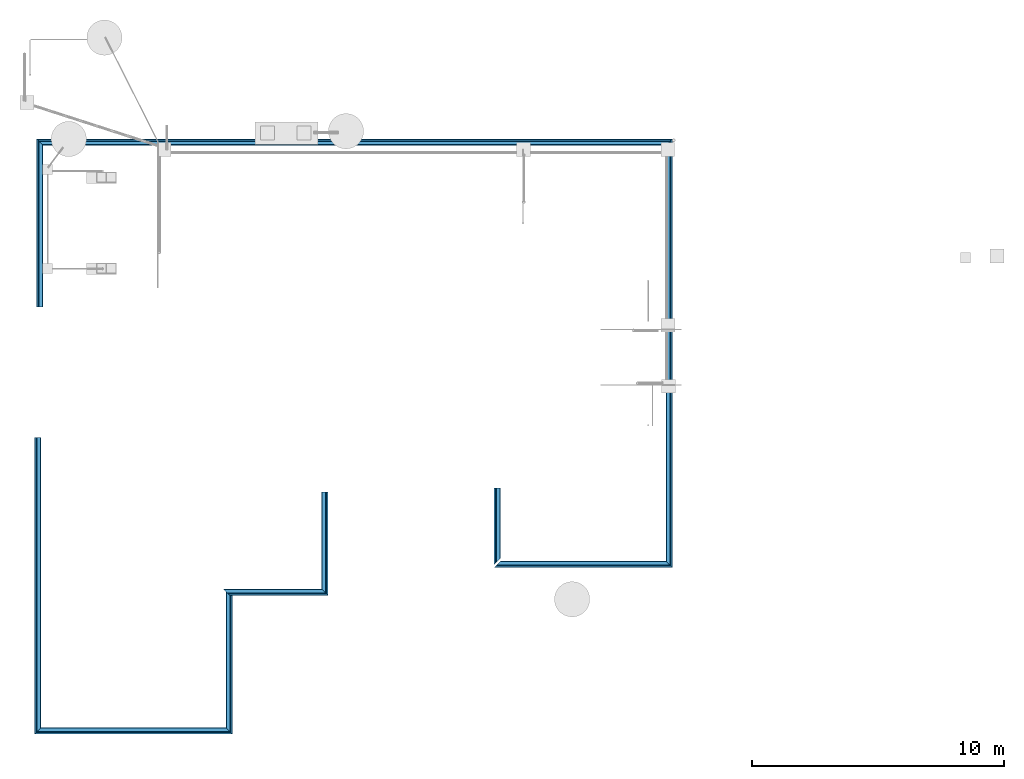
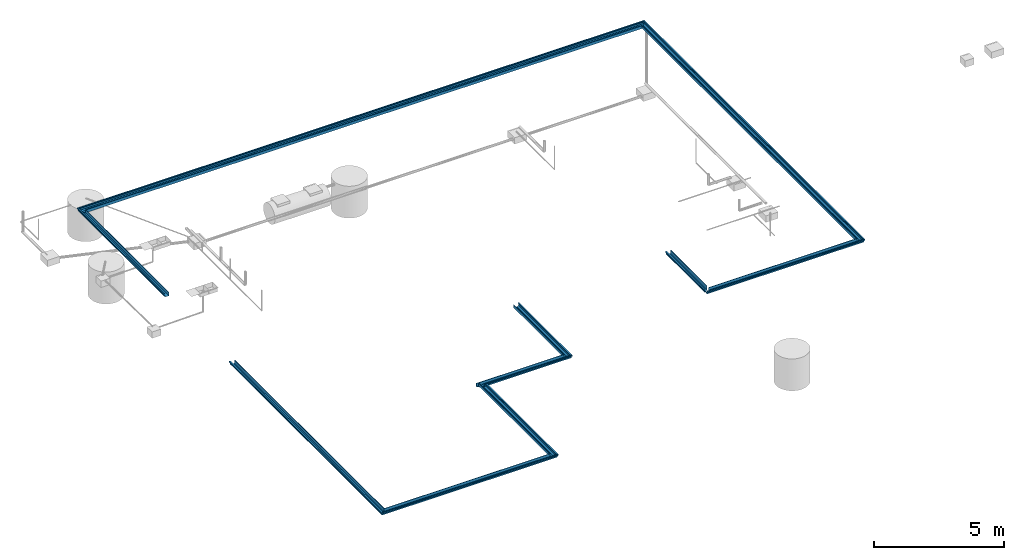
# One storey, part 1 of 15: 10 beams.
"""IFC4X3_ADD2 building model written with IfcOpenShell, lengths in metres."""

from ifc_helpers import new_model, entity, si_unit, converted_unit, frame, origin_with_axes, origin_2d_with_axis, place, context, subcontext, project, spatial, indexed_curve, outline, extrude, clip, halfspace, material, material_profile, profile_set, profile_usage, type_object, element, save


model = new_model("IFC4X3_ADD2")

# Units and contexts
model_context = context("Model", 3, precision=1e-05, world=origin_with_axes())
plan_context = context("Plan", 2, precision=1e-05, world=origin_2d_with_axis())
body_context = subcontext(model_context, "Body", "Model", "MODEL_VIEW")
ifc_project = project(units=[si_unit("VOLUMEUNIT", "CUBIC_METRE"), si_unit("LENGTHUNIT", "METRE"), converted_unit("PLANEANGLEUNIT", "degree", entity("IfcReal", 0.0174532925199433), si_unit("PLANEANGLEUNIT", "RADIAN"), dimensions=[0, 0, 0, 0, 0, 0, 0]), si_unit("AREAUNIT", "SQUARE_METRE")], contexts=[model_context, plan_context])

# Site, building, storey
site_placement = place(None, origin_with_axes())
site = spatial("IfcSite", under=ifc_project, at=site_placement)
building_placement = place(site_placement, origin_with_axes())
building = spatial("IfcBuilding", under=site, at=building_placement, Name="Building")
storey_placement = place(building_placement, origin_with_axes())
storey = spatial("IfcBuildingStorey", under=building, at=storey_placement, Name="Plumbing")

# Beams
ifc_material = material()
ifc_material_profile = material_profile(ifc_material, outline(indexed_curve([(0.0547780841588974, 0.171695500612259), (0.00199998915195465, 0.171695500612259), (0.00199998915195465, 0.1240024715662), (0.0302818566560745, 0.117101639509201), (0.0306723266839981, 0.0436442792415619), (0.0996257215738297, 0.00251318514347076), (0.234851494431496, 0.00200749933719635), (0.234703853726387, 0.149372100830078), (0.25673508644104, 0.149371698498726), (0.25673508644104, 0.14737169444561), (0.236705854535103, 0.147372096776962), (0.236853525042534, 0.0), (0.0990710705518723, 0.000515252351760864), (0.028678372502327, 0.0425049066543579), (0.0282901674509048, 0.11552894115448), (0.0, 0.122431799769402), (0.0, 0.173695504665375), (0.0567780882120132, 0.173695504665375), (0.0567780882120132, 0.149372100830078), (0.0547781139612198, 0.149371698498726), (0.0547780841588974, 0.171695500612259)])))
ifc_profile_set = profile_set([ifc_material_profile])
ifc_profile_usage_1 = profile_usage(ifc_profile_set, cardinal=5)
beam_type = type_object("IfcBeamType", Name="Gutter", PredefinedType="BEAM", material=ifc_profile_set)
beam_1_placement = place(storey_placement, frame((4.24730682373047, 3.78785061836243, 2.80548238754272), z_axis=(0.999999999999994, -7.54979012640429e-08, 7.54979012640429e-08), x_axis=(7.54979012640431e-08, 0.999999999999997, 7.16093850883224e-15)))
element("IfcBeam", 1, at=beam_1_placement, inside=storey, type_object=beam_type, material=ifc_profile_usage_1, Name="Beam", context=body_context, shape_type="Clipping", body=[
    clip(clip(extrude(outline(indexed_curve([(0.0547780841588974, 0.171695500612259), (0.00199998915195465, 0.171695500612259), (0.00199998915195465, 0.1240024715662), (0.0302818566560745, 0.117101639509201), (0.0306723266839981, 0.0436442792415619), (0.0996257215738297, 0.00251318514347076), (0.234851494431496, 0.00200749933719635), (0.234703853726387, 0.149372100830078), (0.25673508644104, 0.149371698498726), (0.25673508644104, 0.14737169444561), (0.236705854535103, 0.147372096776962), (0.236853525042534, 0.0), (0.0990710705518723, 0.000515252351760864), (0.028678372502327, 0.0425049066543579), (0.0282901674509048, 0.11552894115448), (0.0, 0.122431799769402), (0.0, 0.173695504665375), (0.0567780882120132, 0.173695504665375), (0.0567780882120132, 0.149372100830078), (0.0547781139612198, 0.149371698498726), (0.0547780841588974, 0.171695500612259)])), origin_with_axes(), (0.0, 0.0, 1.0), 7.85590360207085), halfspace(frame((-2.78325899216725e-07, -2.80548214912415, 7.85590362548828), z_axis=(0.707107841968536, 4.15994753292896e-14, 0.707105755805969), x_axis=(5.88304539424704e-14, -1.0, 0.0)), False)), halfspace(frame((8.22441279524355e-08, -2.80548286437988, -2.85974806502054e-07), z_axis=(0.707106411457062, 1.06770237096043e-07, -0.707107186317444), x_axis=(1.50995996311265e-07, -0.999999999999989, 0.0)), False)),
])
ifc_profile_usage_2 = profile_usage(ifc_profile_set, cardinal=5)
beam_2_placement = place(storey_placement, frame((12.1032104492188, 3.78784966468811, 2.80548238754272), z_axis=(1.5099578831723e-07, 0.999999999999986, 7.54979012640422e-08), x_axis=(-0.999999999999986, 1.50995802528084e-07, -7.54979510020338e-08)))
element("IfcBeam", 2, at=beam_2_placement, inside=storey, type_object=beam_type, material=ifc_profile_usage_2, Name="Beam", context=body_context, shape_type="Clipping", body=[
    clip(clip(extrude(outline(indexed_curve([(0.0547780841588974, 0.171695500612259), (0.00199998915195465, 0.171695500612259), (0.00199998915195465, 0.1240024715662), (0.0302818566560745, 0.117101639509201), (0.0306723266839981, 0.0436442792415619), (0.0996257215738297, 0.00251318514347076), (0.234851494431496, 0.00200749933719635), (0.234703853726387, 0.149372100830078), (0.25673508644104, 0.149371698498726), (0.25673508644104, 0.14737169444561), (0.236705854535103, 0.147372096776962), (0.236853525042534, 0.0), (0.0990710705518723, 0.000515252351760864), (0.028678372502327, 0.0425049066543579), (0.0282901674509048, 0.11552894115448), (0.0, 0.122431799769402), (0.0, 0.173695504665375), (0.0567780882120132, 0.173695504665375), (0.0567780882120132, 0.149372100830078), (0.0547781139612198, 0.149371698498726), (0.0547780841588974, 0.171695500612259)])), origin_with_axes(), (0.0, 0.0, 1.0), 5.76167405967847), halfspace(frame((-3.81725044462655e-07, -2.80548143386841, -3.18233162488468e-07), z_axis=(0.707105696201324, 5.33851469697311e-08, -0.707107901573181), x_axis=(7.54981147182433e-08, -0.999999999999997, 0.0)), False)), halfspace(frame((0.256735324859619, -2.80548310279846, 5.76167345046997), z_axis=(-0.707106649875641, -1.37678796363616e-07, 0.70710688829422), x_axis=(-1.94707257226088e-07, 0.999999999999981, 0.0)), False)),
])
ifc_profile_usage_3 = profile_usage(ifc_profile_set, cardinal=5)
beam_3_placement = place(storey_placement, frame((4.24730968475342, 15.5573244094849, 2.80548238754272), z_axis=(-2.38418579101555e-07, -0.999999999999969, 7.5497901264041e-08), x_axis=(0.999999999999969, -2.38418579101555e-07, -7.54979296857504e-08)))
element("IfcBeam", 3, at=beam_3_placement, inside=storey, type_object=beam_type, material=ifc_profile_usage_3, Name="Beam", context=body_context, shape_type="Clipping", body=[
    clip(extrude(outline(indexed_curve([(0.0547780841588974, 0.171695500612259), (0.00199998915195465, 0.171695500612259), (0.00199998915195465, 0.1240024715662), (0.0302818566560745, 0.117101639509201), (0.0306723266839981, 0.0436442792415619), (0.0996257215738297, 0.00251318514347076), (0.234851494431496, 0.00200749933719635), (0.234703853726387, 0.149372100830078), (0.25673508644104, 0.149371698498726), (0.25673508644104, 0.14737169444561), (0.236705854535103, 0.147372096776962), (0.236853525042534, 0.0), (0.0990710705518723, 0.000515252351760864), (0.028678372502327, 0.0425049066543579), (0.0282901674509048, 0.11552894115448), (0.0, 0.122431799769402), (0.0, 0.173695504665375), (0.0567780882120132, 0.173695504665375), (0.0567780882120132, 0.149372100830078), (0.0547781139612198, 0.149371698498726), (0.0547780841588974, 0.171695500612259)])), origin_with_axes(), (0.0, 0.0, 1.0), 11.769474853624), halfspace(frame((-4.2625677565411e-07, -2.80548357963562, 11.769474029541), z_axis=(0.707107305526733, -5.3385036835607e-08, 0.707106292247772), x_axis=(-7.54977871369037e-08, -0.999999999999997, 0.0)), False)),
])
ifc_profile_usage_4 = profile_usage(ifc_profile_set, cardinal=5)
beam_4_placement = place(storey_placement, frame((11.7348031997681, 9.2927885055542, 2.8054826259613), z_axis=(0.999999999999978, -1.94707183709393e-07, 7.54979012640417e-08), x_axis=(1.94707183709392e-07, 0.999999999999974, -1.19209275339923e-07)))
element("IfcBeam", 4, at=beam_4_placement, inside=storey, type_object=beam_type, material=ifc_profile_usage_4, Name="Beam", context=body_context, shape_type="Clipping", body=[
    clip(clip(extrude(outline(indexed_curve([(0.0547780841588974, 0.171695500612259), (0.00199998915195465, 0.171695500612259), (0.00199998915195465, 0.1240024715662), (0.0302818566560745, 0.117101639509201), (0.0306723266839981, 0.0436442792415619), (0.0996257215738297, 0.00251318514347076), (0.234851494431496, 0.00200749933719635), (0.234703853726387, 0.149372100830078), (0.25673508644104, 0.149371698498726), (0.25673508644104, 0.14737169444561), (0.236705854535103, 0.147372096776962), (0.236853525042534, 0.0), (0.0990710705518723, 0.000515252351760864), (0.028678372502327, 0.0425049066543579), (0.0282901674509048, 0.11552894115448), (0.0, 0.122431799769402), (0.0, 0.173695504665375), (0.0567780882120132, 0.173695504665375), (0.0567780882120132, 0.149372100830078), (0.0547781139612198, 0.149371698498726), (0.0547780841588974, 0.171695500612259)])), origin_with_axes(), (0.0, 0.0, 1.0), 4.15980045426904), halfspace(frame((0.256735235452652, -2.65728807449341, -9.05686306396092e-07), z_axis=(-0.707105576992035, -3.5527136788005e-15, -0.707108020782471), x_axis=(-5.02430442411928e-15, 1.0, 0.0)), False)), halfspace(frame((2.33770819590973e-07, -2.65728807449341, 4.15980052947998), z_axis=(0.707105576992035, 4.61852778244065e-14, 0.707108020782471), x_axis=(6.53159575135507e-14, -1.0, 0.0)), False)),
])
ifc_profile_usage_5 = profile_usage(ifc_profile_set, cardinal=5)
beam_5_placement = place(storey_placement, frame((15.894603729248, 9.29278755187988, 2.80548286437988), z_axis=(1.5099578831723e-07, 0.999999999999986, 7.54979012640422e-08), x_axis=(-0.999999999999986, 1.50995802528084e-07, -7.54979936345979e-08)))
element("IfcBeam", 5, at=beam_5_placement, inside=storey, type_object=beam_type, material=ifc_profile_usage_5, Name="Beam", context=body_context, shape_type="Clipping", body=[
    clip(extrude(outline(indexed_curve([(0.0547780841588974, 0.171695500612259), (0.00199998915195465, 0.171695500612259), (0.00199998915195465, 0.1240024715662), (0.0302818566560745, 0.117101639509201), (0.0306723266839981, 0.0436442792415619), (0.0996257215738297, 0.00251318514347076), (0.234851494431496, 0.00200749933719635), (0.234703853726387, 0.149372100830078), (0.25673508644104, 0.149371698498726), (0.25673508644104, 0.14737169444561), (0.236705854535103, 0.147372096776962), (0.236853525042534, 0.0), (0.0990710705518723, 0.000515252351760864), (0.028678372502327, 0.0425049066543579), (0.0282901674509048, 0.11552894115448), (0.0, 0.122431799769402), (0.0, 0.173695504665375), (0.0567780882120132, 0.173695504665375), (0.0567780882120132, 0.149372100830078), (0.0547781139612198, 0.149371698498726), (0.0547780841588974, 0.171695500612259)])), origin_with_axes(), (0.0, 0.0, 1.0), 4.10537048861072), halfspace(frame((4.49497520094155e-07, -2.65728807449341, -4.61004447060986e-07), z_axis=(0.707108020782471, 1.37678540568231e-07, -0.707105576992035), x_axis=(1.94706517988406e-07, -0.999999999999981, 0.0)), False)),
])
ifc_profile_usage_6 = profile_usage(ifc_profile_set, cardinal=5)
beam_6_placement = place(storey_placement, frame((22.4811115264893, 13.5445785522461, 2.80548238754272), z_axis=(-3.5762786865232e-07, -0.999999999999933, 7.54979012640383e-08), x_axis=(0.999999999999923, -3.57627868652316e-07, 1.62920684942934e-07)))
element("IfcBeam", 6, at=beam_6_placement, inside=storey, type_object=beam_type, material=ifc_profile_usage_6, Name="Beam", context=body_context, shape_type="Clipping", body=[
    clip(extrude(outline(indexed_curve([(0.0547780841588974, 0.171695500612259), (0.00199998915195465, 0.171695500612259), (0.00199998915195465, 0.1240024715662), (0.0302818566560745, 0.117101639509201), (0.0306723266839981, 0.0436442792415619), (0.0996257215738297, 0.00251318514347076), (0.234851494431496, 0.00200749933719635), (0.234703853726387, 0.149372100830078), (0.25673508644104, 0.149371698498726), (0.25673508644104, 0.14737169444561), (0.236705854535103, 0.147372096776962), (0.236853525042534, 0.0), (0.0990710705518723, 0.000515252351760864), (0.028678372502327, 0.0425049066543579), (0.0282901674509048, 0.11552894115448), (0.0, 0.122431799769402), (0.0, 0.173695504665375), (0.0567780882120132, 0.173695504665375), (0.0567780882120132, 0.149372100830078), (0.0547781139612198, 0.149371698498726), (0.0547780841588974, 0.171695500612259)])), origin_with_axes(), (0.0, 0.0, 1.0), 3.03872874959891), halfspace(frame((-1.84983571216435e-06, -2.82755851745605, 3.0387282371521), z_axis=(0.70710700750351, 3.09086267691328e-08, 0.707106530666351), x_axis=(4.37113851809471e-08, -0.999999999999999, 0.0)), False)),
])
ifc_profile_usage_7 = profile_usage(ifc_profile_set, cardinal=5)
beam_7_placement = place(storey_placement, frame((29.5532684326172, 10.3937425613403, 2.80548238754272), z_axis=(1.5099578831723e-07, 0.999999999999986, 7.54979012640422e-08), x_axis=(-0.999999999999986, 1.50995802528084e-07, -7.54980646888715e-08)))
element("IfcBeam", 7, at=beam_7_placement, inside=storey, type_object=beam_type, material=ifc_profile_usage_7, Name="Beam", context=body_context, shape_type="Clipping", body=[
    clip(clip(extrude(outline(indexed_curve([(0.0547780841588974, 0.171695500612259), (0.00199998915195465, 0.171695500612259), (0.00199998915195465, 0.1240024715662), (0.0302818566560745, 0.117101639509201), (0.0306723266839981, 0.0436442792415619), (0.0996257215738297, 0.00251318514347076), (0.234851494431496, 0.00200749933719635), (0.234703853726387, 0.149372100830078), (0.25673508644104, 0.149371698498726), (0.25673508644104, 0.14737169444561), (0.236705854535103, 0.147372096776962), (0.236853525042534, 0.0), (0.0990710705518723, 0.000515252351760864), (0.028678372502327, 0.0425049066543579), (0.0282901674509048, 0.11552894115448), (0.0, 0.122431799769402), (0.0, 0.173695504665375), (0.0567780882120132, 0.173695504665375), (0.0567780882120132, 0.149372100830078), (0.0547781139612198, 0.149371698498726), (0.0547780841588974, 0.171695500612259)])), origin_with_axes(), (0.0, 0.0, 1.0), 17.0083696294259), halfspace(frame((-3.37937393624088e-07, -2.80548143386841, -3.05952113421881e-07), z_axis=(0.707106649875641, 1.37678810574471e-07, -0.70710688829422), x_axis=(1.94707277323275e-07, -0.999999999999981, 0.0)), False)), halfspace(frame((3.22906203109596e-07, -2.80549144744873, 17.0083637237549), z_axis=(0.70710688829422, -3.06266144889378e-07, 0.707106649875641), x_axis=(-4.33125670191343e-07, -0.999999999999906, 0.0)), False)),
])
ifc_profile_usage_8 = profile_usage(ifc_profile_set, cardinal=5)
beam_8_placement = place(storey_placement, frame((22.4811096191406, 10.3937463760376, 2.80548238754272), z_axis=(0.999999999999903, -4.33125762810918e-07, 7.5497901264036e-08), x_axis=(4.33125762810916e-07, 0.999999999999899, -1.1920926112906e-07)))
element("IfcBeam", 8, at=beam_8_placement, inside=storey, type_object=beam_type, material=ifc_profile_usage_8, Name="Beam", context=body_context, shape_type="Clipping", body=[
    clip(clip(extrude(outline(indexed_curve([(0.0547780841588974, 0.171695500612259), (0.00199998915195465, 0.171695500612259), (0.00199998915195465, 0.1240024715662), (0.0302818566560745, 0.117101639509201), (0.0306723266839981, 0.0436442792415619), (0.0996257215738297, 0.00251318514347076), (0.234851494431496, 0.00200749933719635), (0.234703853726387, 0.149372100830078), (0.25673508644104, 0.149371698498726), (0.25673508644104, 0.14737169444561), (0.236705854535103, 0.147372096776962), (0.236853525042534, 0.0), (0.0990710705518723, 0.000515252351760864), (0.028678372502327, 0.0425049066543579), (0.0282901674509048, 0.11552894115448), (0.0, 0.122431799769402), (0.0, 0.173695504665375), (0.0567780882120132, 0.173695504665375), (0.0567780882120132, 0.149372100830078), (0.0547781139612198, 0.149371698498726), (0.0547780841588974, 0.171695500612259)])), origin_with_axes(), (0.0, 0.0, 1.0), 7.07215882531267), halfspace(frame((2.00403235339763e-07, -2.80548000335693, -2.59445027950278e-06), z_axis=(0.707106471061707, -6.1817303276257e-08, -0.707107067108154), x_axis=(-8.74229070247926e-08, -0.999999999999996, 0.0)), False)), halfspace(frame((-5.51158450434741e-07, -2.80548191070557, 7.0721583366394), z_axis=(0.707107067108154, 1.17239551400417e-13, 0.707106471061707), x_axis=(1.65801696594392e-13, -1.0, 0.0)), False)),
])
ifc_profile_usage_9 = profile_usage(ifc_profile_set, cardinal=5)
beam_9_placement = place(storey_placement, frame((4.32292366027832, 27.40212059021, 2.80548238754272), z_axis=(-2.38418579101555e-07, -0.999999999999969, 7.5497901264041e-08), x_axis=(0.999999999999969, -2.38418579101555e-07, -7.54979296857504e-08)))
element("IfcBeam", 9, at=beam_9_placement, inside=storey, type_object=beam_type, material=ifc_profile_usage_9, Name="Beam", context=body_context, shape_type="Clipping", body=[
    clip(extrude(outline(indexed_curve([(0.0547780841588974, 0.171695500612259), (0.00199998915195465, 0.171695500612259), (0.00199998915195465, 0.1240024715662), (0.0302818566560745, 0.117101639509201), (0.0306723266839981, 0.0436442792415619), (0.0996257215738297, 0.00251318514347076), (0.234851494431496, 0.00200749933719635), (0.234703853726387, 0.149372100830078), (0.25673508644104, 0.149371698498726), (0.25673508644104, 0.14737169444561), (0.236705854535103, 0.147372096776962), (0.236853525042534, 0.0), (0.0990710705518723, 0.000515252351760864), (0.028678372502327, 0.0425049066543579), (0.0282901674509048, 0.11552894115448), (0.0, 0.122431799769402), (0.0, 0.173695504665375), (0.0567780882120132, 0.173695504665375), (0.0567780882120132, 0.149372100830078), (0.0547781139612198, 0.149371698498726), (0.0547780841588974, 0.171695500612259)])), origin_with_axes(), (0.0, 0.0, 1.0), 6.66895096108743), halfspace(frame((-3.34290376713398e-07, -2.80549240112305, 2.78403126685589e-06), z_axis=(0.707106590270996, -1.99496057007309e-07, -0.707106947898865), x_axis=(-2.82130105633501e-07, -0.99999999999996, 0.0)), False)),
])
ifc_profile_usage_10 = profile_usage(ifc_profile_set, cardinal=5)
beam_10_placement = place(storey_placement, frame((29.5532722473145, 27.4021091461182, 2.80548238754272), z_axis=(-0.999999999999862, 5.20548553595218e-07, 7.54979012640329e-08), x_axis=(-5.20548553595187e-07, -0.999999999999801, 3.57627897073982e-07)))
element("IfcBeam", 10, at=beam_10_placement, inside=storey, type_object=beam_type, material=ifc_profile_usage_10, Name="Beam", context=body_context, shape_type="Clipping", body=[
    clip(clip(extrude(outline(indexed_curve([(0.0547780841588974, 0.171695500612259), (0.00199998915195465, 0.171695500612259), (0.00199998915195465, 0.1240024715662), (0.0302818566560745, 0.117101639509201), (0.0306723266839981, 0.0436442792415619), (0.0996257215738297, 0.00251318514347076), (0.234851494431496, 0.00200749933719635), (0.234703853726387, 0.149372100830078), (0.25673508644104, 0.149371698498726), (0.25673508644104, 0.14737169444561), (0.236705854535103, 0.147372096776962), (0.236853525042534, 0.0), (0.0990710705518723, 0.000515252351760864), (0.028678372502327, 0.0425049066543579), (0.0282901674509048, 0.11552894115448), (0.0, 0.122431799769402), (0.0, 0.173695504665375), (0.0567780882120132, 0.173695504665375), (0.0567780882120132, 0.149372100830078), (0.0547781139612198, 0.149371698498726), (0.0547780841588974, 0.171695500612259)])), origin_with_axes(), (0.0, 0.0, 1.0), 25.2303487016253), halfspace(frame((-1.25125296790429e-07, -2.65729451179504, 2.82003588836233e-06), z_axis=(0.707106411457062, 1.27843819086593e-07, -0.707107126712799), x_axis=(1.80798557353137e-07, -0.999999999999984, 0.0)), False)), halfspace(frame((1.56440262344404e-06, -2.65729880332947, 25.2303504943848), z_axis=(0.707107126712799, 2.10733723804424e-08, 0.707106411457062), x_axis=(2.98022344625606e-08, -1.0, 0.0)), False)),
])

save(model, "model.ifc")
